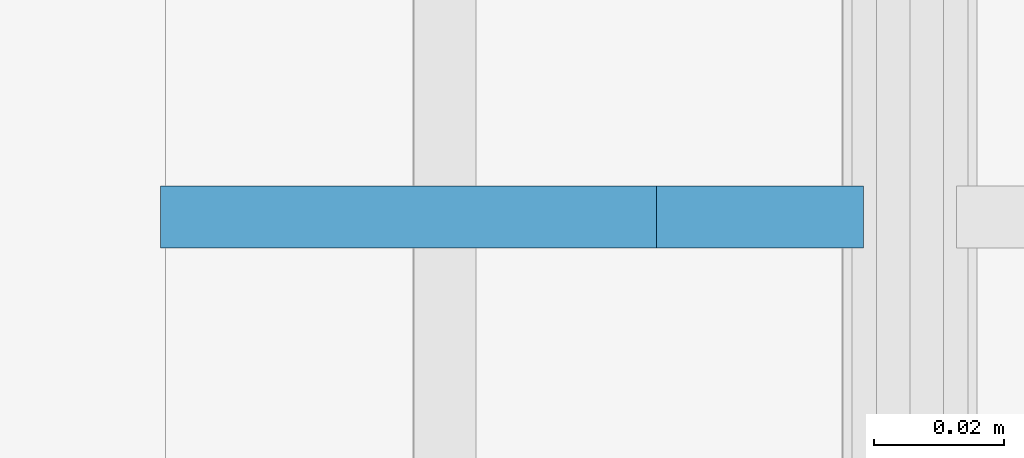
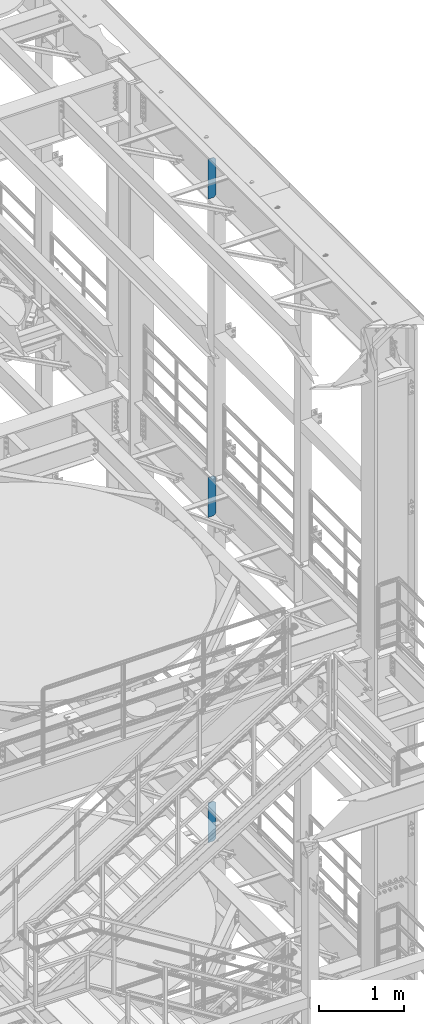
# One storey, part 1572 of 1876: 3 plates, 3 elements without a shape of their own.
"""IFC2X3 building model written with IfcOpenShell, lengths in millimetres."""

from ifc_helpers import new_model, si_unit, frame, origin_with_axes, place, context, subcontext, project, spatial, faceted_brep, material, type_object, element, aggregate, save


model = new_model("IFC2X3")

# Units and contexts
model_context = context("Model", 3, precision=1e-05, world=origin_with_axes())
body_context = subcontext(model_context, "Body", "Model", "MODEL_VIEW")
ifc_project = project(units=[si_unit("LENGTHUNIT", "METRE", prefix="MILLI"), si_unit("AREAUNIT", "SQUARE_METRE"), si_unit("VOLUMEUNIT", "CUBIC_METRE"), si_unit("MASSUNIT", "GRAM", prefix="KILO"), si_unit("TIMEUNIT", "SECOND"), si_unit("PLANEANGLEUNIT", "RADIAN"), si_unit("SOLIDANGLEUNIT", "STERADIAN"), si_unit("THERMODYNAMICTEMPERATUREUNIT", "DEGREE_CELSIUS"), si_unit("LUMINOUSINTENSITYUNIT", "LUMEN")], contexts=[model_context])

# Site, building, storey
site_placement = place(None, origin_with_axes())
site = spatial("IfcSite", under=ifc_project, at=site_placement, CompositionType="ELEMENT")
building_placement = place(site_placement, origin_with_axes())
building = spatial("IfcBuilding", under=site, at=building_placement, Name="Undefined", CompositionType="ELEMENT")
storey_placement = place(building_placement, origin_with_axes())
storey = spatial("IfcBuildingStorey", under=building, at=storey_placement, Name="Undefined", CompositionType="ELEMENT", Elevation=0.0)

# Assembly, plate
assembly_1_placement = place(storey_placement, origin_with_axes())
assembly_1 = element("IfcElementAssembly", 1, at=assembly_1_placement, inside=storey, Name="BEAM", AssemblyPlace="NOTDEFINED", PredefinedType="RIGID_FRAME")
ifc_material = material(Name="STEEL/A36")
plate_type = type_object("IfcPlateType", PredefinedType="NOTDEFINED")
plate_1_placement = place(assembly_1_placement, frame((7612.85625, -508.0, 21958.3), z_axis=(0.0, 0.0, 1.0), x_axis=(-1.0, 0.0, 0.0)))
plate_1 = element("IfcPlate", 2, at=plate_1_placement, type_object=plate_type, material=ifc_material, Name="PLATE", context=body_context, shape_type="Brep", body=[
    faceted_brep([(-9.76996261670138e-14, -4.76250000000073, 31.75), (0.0, -4.76249999999982, 539.75), (0.0, 4.76249999999982, 539.75), (-9.76996261670138e-14, 4.76250000000073, 31.75), (31.75, -4.76249999999982, 571.5), (31.75, 4.76249999999982, 571.5), (107.949996948242, -4.76249999999982, 571.5), (107.949996948242, 4.76249999999982, 571.5), (107.950006484985, -4.76250000000073, 0.0), (107.950006484985, 4.76250000000073, 0.0), (31.75, -4.76250000000073, 0.0), (31.75, 4.76250000000073, 0.0)], [[[0, 1, 2, 3]], [[1, 4, 5, 2]], [[4, 6, 7, 5]], [[6, 8, 9, 7]], [[8, 10, 11, 9]], [[10, 0, 3, 11]], [[5, 7, 9, 11, 3, 2]], [[10, 8, 6, 4, 1, 0]]]),
])
aggregate(assembly_1, [plate_1])

assembly_2_placement = place(storey_placement, origin_with_axes())
assembly_2 = element("IfcElementAssembly", 3, at=assembly_2_placement, inside=storey, Name="BEAM", AssemblyPlace="NOTDEFINED", PredefinedType="RIGID_FRAME")
plate_2_placement = place(assembly_2_placement, frame((7612.85624694824, -508.0, 17386.3), z_axis=(0.0, 0.0, 1.0), x_axis=(-1.0, 0.0, 0.0)))
plate_2 = element("IfcPlate", 4, at=plate_2_placement, type_object=plate_type, material=ifc_material, Name="PLATE", context=body_context, shape_type="Brep", body=[
    faceted_brep([(-9.76996261670138e-14, -4.76250000000073, 31.75), (0.0, -4.76249999999982, 539.75), (0.0, 4.76249999999982, 539.75), (-9.76996261670138e-14, 4.76250000000073, 31.75), (31.75, -4.76249999999982, 571.5), (31.75, 4.76249999999982, 571.5), (107.949996948242, -4.76249999999982, 571.5), (107.949996948242, 4.76249999999982, 571.5), (107.950006484985, -4.76250000000073, 0.0), (107.950006484985, 4.76250000000073, 0.0), (31.75, -4.76250000000073, 0.0), (31.75, 4.76250000000073, 0.0)], [[[0, 1, 2, 3]], [[1, 4, 5, 2]], [[4, 6, 7, 5]], [[6, 8, 9, 7]], [[8, 10, 11, 9]], [[10, 0, 3, 11]], [[5, 7, 9, 11, 3, 2]], [[10, 8, 6, 4, 1, 0]]]),
])
aggregate(assembly_2, [plate_2])

assembly_3_placement = place(storey_placement, origin_with_axes())
assembly_3 = element("IfcElementAssembly", 5, at=assembly_3_placement, inside=storey, Name="BEAM", AssemblyPlace="NOTDEFINED", PredefinedType="RIGID_FRAME")
plate_3_placement = place(assembly_3_placement, frame((7612.85625, -508.0, 12712.7), z_axis=(0.0, 0.0, 1.0), x_axis=(-1.0, 0.0, 0.0)))
plate_3 = element("IfcPlate", 6, at=plate_3_placement, type_object=plate_type, material=ifc_material, Name="PLATE", context=body_context, shape_type="Brep", body=[
    faceted_brep([(-9.76996261670138e-14, -4.76250000000073, 31.75), (0.0, -4.76249999999982, 539.75), (0.0, 4.76249999999982, 539.75), (-9.76996261670138e-14, 4.76250000000073, 31.75), (31.75, -4.76249999999982, 571.5), (31.75, 4.76249999999982, 571.5), (107.949996948242, -4.76249999999982, 571.5), (107.949996948242, 4.76249999999982, 571.5), (107.950006484985, -4.76250000000073, 0.0), (107.950006484985, 4.76250000000073, 0.0), (31.75, -4.76250000000073, 0.0), (31.75, 4.76250000000073, 0.0)], [[[0, 1, 2, 3]], [[1, 4, 5, 2]], [[4, 6, 7, 5]], [[6, 8, 9, 7]], [[8, 10, 11, 9]], [[10, 0, 3, 11]], [[5, 7, 9, 11, 3, 2]], [[10, 8, 6, 4, 1, 0]]]),
])
aggregate(assembly_3, [plate_3])

save(model, "model.ifc")
